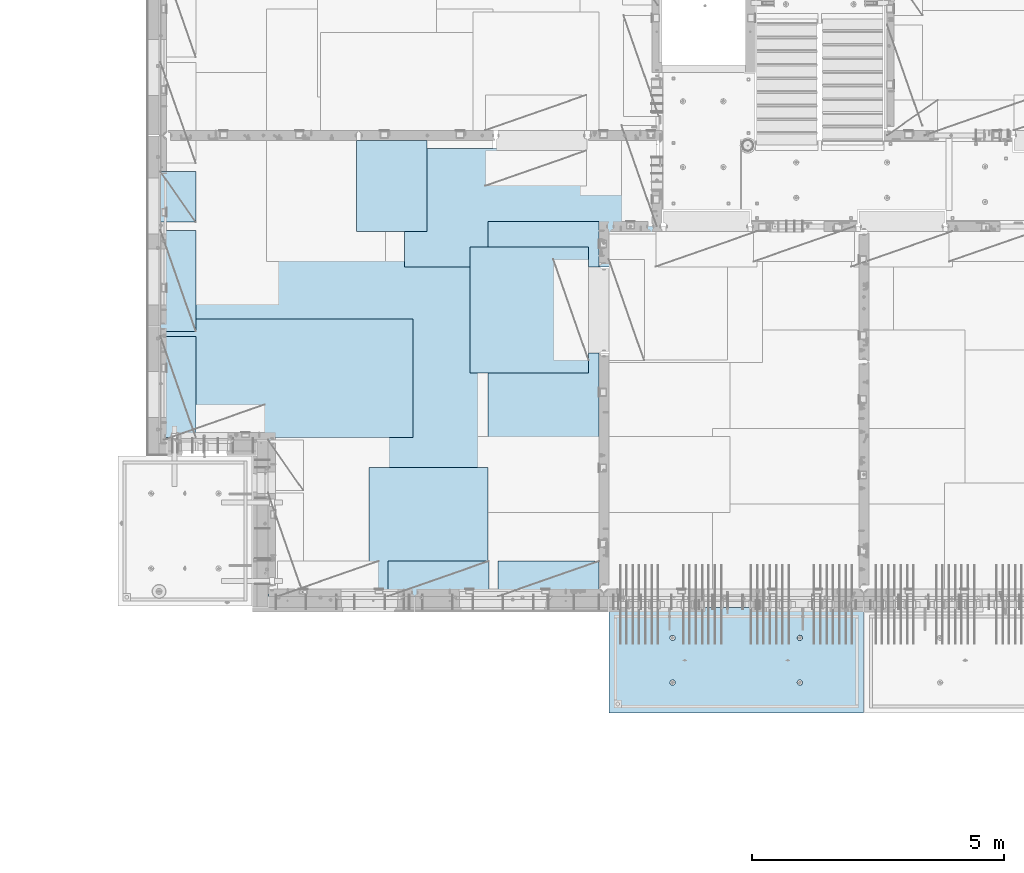
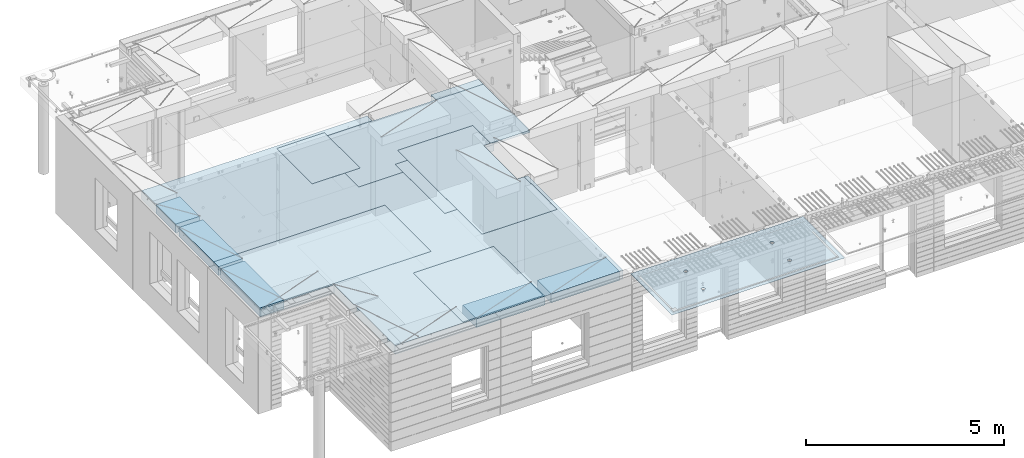
# One storey, part 201 of 350: 11 plates, 2 slabs, 11 elements without a shape of their own.
"""IFC2X3 building model written with IfcOpenShell, lengths in millimetres."""

from ifc_helpers import new_model, si_unit, frame, origin_with_axes, place, context, subcontext, project, spatial, faceted_brep, material, type_object, element, aggregate, save


model = new_model("IFC2X3")

# Units and contexts
model_context = context("Model", 3, precision=1e-05, world=origin_with_axes())
body_context = subcontext(model_context, "Body", "Model", "MODEL_VIEW")
ifc_project = project(units=[si_unit("LENGTHUNIT", "METRE", prefix="MILLI"), si_unit("AREAUNIT", "SQUARE_METRE"), si_unit("VOLUMEUNIT", "CUBIC_METRE"), si_unit("MASSUNIT", "GRAM", prefix="KILO"), si_unit("TIMEUNIT", "SECOND"), si_unit("PLANEANGLEUNIT", "RADIAN"), si_unit("SOLIDANGLEUNIT", "STERADIAN"), si_unit("THERMODYNAMICTEMPERATUREUNIT", "DEGREE_CELSIUS"), si_unit("LUMINOUSINTENSITYUNIT", "LUMEN")], contexts=[model_context])

# Site, building, storey
site_placement = place(None, origin_with_axes())
site = spatial("IfcSite", under=ifc_project, at=site_placement, CompositionType="ELEMENT")
building_placement = place(site_placement, origin_with_axes())
building = spatial("IfcBuilding", under=site, at=building_placement, CompositionType="ELEMENT")
storey_placement = place(building_placement, origin_with_axes())
storey = spatial("IfcBuildingStorey", under=building, at=storey_placement, Name="2", CompositionType="ELEMENT", Elevation=0.0)

# Assembly, slab
assembly_1_placement = place(storey_placement, origin_with_axes())
assembly_1 = element("IfcElementAssembly", 1, at=assembly_1_placement, inside=storey, AssemblyPlace="NOTDEFINED", PredefinedType="REINFORCEMENT_UNIT")
ifc_material_1 = material(Name="CONCRETE/C35/45")
slab_type_1 = type_object("IfcSlabType", PredefinedType="NOTDEFINED")
slab_1_placement = place(assembly_1_placement, frame((21799.9998568133, 7629.99655735226, 87720.0), z_axis=(-1.11800000013248e-06, -0.999999999999375, 0.0), x_axis=(-0.999999999999093, 1.34699999998405e-06, 0.0)))
slab_1 = element("IfcSlab", 2, at=slab_1_placement, type_object=slab_type_1, material=ifc_material_1, PredefinedType="FLOOR", context=body_context, shape_type="Brep", body=[
    faceted_brep([(3730.38290548735, -4.08996566387941, 616.12216176429), (3731.90567362447, 10.0, 615.627386703446), (3739.08833473806, 10.0, 629.724200466487), (3737.80580686752, -3.95055250760925, 630.656008831066), (3750.27560641379, 10.0, 640.911502705889), (3749.35118053074, -3.83997377335618, 642.183862123165), (3764.37240055375, 10.0, 648.094202331947), (3763.88889206625, -3.76900584615942, 649.582281527485), (3779.99882472937, 10.0, 650.569206660445), (3779.99882259584, -3.74455690493051, 652.131088126915), (3795.62525566664, 10.0, 648.094245023346), (3796.1087600739, -3.76900542440126, 649.582325494244), (3809.72206942968, 10.0, 640.911583909758), (3810.64649178305, -3.83997297089081, 642.183945778786), (3820.90937166908, 10.0, 629.724312234022), (3822.19189689232, -3.95055140258046, 630.656124028656), (3828.09207129514, 10.0, 615.627518094066), (3829.61483794004, -4.08996436404414, 616.122297269464), (3830.56707562364, 10.0, 600.001093918447), (3832.18578061358, -4.24460391153116, 600.001096129598), (3828.09211398654, 10.0, 584.374662981175), (3829.64831848373, -4.39934773846471, 583.869023838871), (3820.90945287295, 10.0, 570.277849218135), (3822.24608208202, -4.53903372617788, 569.306734043194), (3809.72218119721, 10.0, 559.090546978732), (3810.70070853473, -4.64994969953841, 557.743723511573), (3795.62538705726, 10.0, 551.907847352675), (3796.14233218844, -4.72119045964791, 550.316861227655), (3779.99896288164, 10.0, 549.432843024176), (3779.99896517058, -4.74574361447594, 547.757190340714), (3764.37253194437, 10.0, 551.907804661275), (3763.85559114489, -4.72119088313775, 550.316817078197), (3750.27571818133, 10.0, 559.090465774863), (3749.29719446955, -4.6499505048414, 557.743639560339), (3739.08841594193, 10.0, 570.277737450599), (3737.75178928409, -4.53903483404429, 569.306618549992), (3731.90571631587, 10.0, 584.374531590555), (3730.34951305942, -4.39934904004622, 583.868888150996), (3729.43071198737, 10.0, 600.000955766174), (3727.81200684201, -4.24460527917836, 600.000953555023), (0.0, 10.0, 0.0), (0.0, -10.0, 0.0), (0.000328360383718973, 10.0, 2085.00366210938), (5040.0, 10.0, -2.18278728425503e-09), (5040.0, -10.0, -2.18278728425503e-09), (5040.00048828125, 10.0, 2085.00366210938), (1210.18496592851, 4.0893025782425, 1468.8123736889), (1210.82376192895, 10.0, 1469.01993205604), (1208.29313952565, 10.0, 1484.99751183111), (1207.63911173254, 4.24455542066426, 1484.99751093771), (1217.61159442581, 3.94915724093153, 1454.20219661341), (1218.16787053537, 10.0, 1454.6063560253), (1229.19498209749, 3.837876675796, 1442.60117732261), (1229.60657282509, 10.0, 1443.16768498606), (1243.80127350603, 3.76640192835475, 1435.14992181469), (1244.02016891989, 10.0, 1435.82361575756), (1259.99775658, 3.74176842256566, 1432.58187432577), (1259.99775560856, 10.0, 1433.29303700502), (1276.19423262309, 3.76640235324157, 1435.14996610939), (1275.97533538363, 10.0, 1435.82365940832), (1290.8005036357, 3.83787748374743, 1442.60126155003), (1290.38891141437, 10.0, 1443.16776801473), (1302.38385956513, 3.94915835243592, 1454.20231248656), (1301.82758245361, 10.0, 1454.60647030446), (1309.81044810845, 4.08930388411682, 1468.81250982317), (1309.17165168211, 10.0, 1469.02006639926), (1312.35625807182, 4.244556792808, 1484.99765398133), (1311.70223043464, 10.0, 1484.99765308793), (1309.77685741928, 4.39970507899125, 1501.17189122433), (1309.17160803135, 10.0, 1500.975232863), (1302.32949611505, 4.53957668620569, 1515.75353188573), (1301.82749942493, 10.0, 1515.38880889374), (1290.74610851982, 4.65051890275208, 1527.31927827547), (1290.3887971352, 10.0, 1526.82747993297), (1276.16055006181, 4.72171992080985, 1534.74199744468), (1275.97520104041, 10.0, 1534.17154916147), (1259.99761353621, 4.74624887190294, 1537.29914508766), (1259.99761435174, 10.0, 1536.70212791401), (1243.83468398195, 4.72171949766926, 1534.74195333328), (1244.02003457667, 10.0, 1534.17150551072), (1229.24914576394, 4.65051809765282, 1527.31919434463), (1229.60645854592, 10.0, 1526.8273969043), (1217.66578971822, 4.53957557752437, 1515.75341630916), (1218.16778750669, 10.0, 1515.38869461457), (1210.21846821205, 4.39970377489226, 1501.17175527336), (1210.82371827819, 10.0, 1500.97509851978), (1210.34950957413, -4.39938207223895, 583.86544460908), (1211.90571640051, 10.0, 584.371089208588), (1209.43071207202, 10.0, 599.997513384207), (1207.81200317426, -4.24463830025343, 599.997511173051), (1217.75178633104, -4.53906787629239, 569.303173961003), (1219.08841602657, 10.0, 570.274295068632), (1229.29719234665, -4.64998355506395, 557.740194139937), (1230.27571826597, 10.0, 559.087023392896), (1243.85559006878, -4.72122393849713, 550.313371123784), (1244.37253202901, 10.0, 551.904362279308), (1259.99896525523, -4.74577667158155, 547.753744202259), (1259.99896296629, 10.0, 549.429400642209), (1276.14233343384, -4.72122351497819, 550.313415273247), (1275.6253871419, 10.0, 551.904404970708), (1290.70071082692, -4.64998274977552, 557.740278091178), (1289.72218128186, 10.0, 559.087104596765), (1302.24608520437, -4.53906676842598, 569.303289454215), (1300.9094529576, 10.0, 570.274406836168), (1309.64832213832, -4.39938077065744, 583.865580296964), (1308.09211407118, 10.0, 584.371220599208), (1312.18578445062, -4.24463693260623, 599.997653747636), (1310.56707570828, 10.0, 599.99765153648), (1309.61484159223, -4.08999737400154, 616.118856046664), (1308.09207137979, 10.0, 615.624075712099), (1302.19190001076, -3.95058440251159, 630.652683850883), (1300.90937175373, 10.0, 629.720869852055), (1290.64649407134, -3.8400059628766, 642.180506429899), (1289.72206951433, 10.0, 640.908141527791), (1276.10876131689, -3.76903841129388, 649.578886677323), (1275.62525575129, 10.0, 648.090802641378), (1259.99882268048, -3.74458989004779, 652.127649493255), (1259.99882481401, 10.0, 650.565764278478), (1243.88889099253, -3.76903883303748, 649.578842710559), (1244.37240063839, 10.0, 648.090759949978), (1229.35117841172, -3.84000676534197, 642.180422774271), (1230.27560649844, 10.0, 640.908060323922), (1217.80580391836, -3.95058550754038, 630.652568653284), (1219.0883348227, 10.0, 629.72075808452), (1210.38290200446, -4.08999867383682, 616.11872054148), (1211.90567370912, 10.0, 615.623944321479), (3795.97520095576, 10.0, 1534.17499154344), (3796.16054881881, 4.72175290768791, 1534.7454362616), (3779.99761345157, 4.74628185702022, 1537.30258372132), (3779.99761426709, 10.0, 1536.70557029598), (3810.38879705055, 10.0, 1526.83092231494), (3810.74610623151, 4.65055189473787, 1527.32271762435), (3821.82749934028, 10.0, 1515.39225127571), (3822.3294929966, 4.53960968612228, 1515.75697206351), (3829.1716079467, 10.0, 1500.97867524496), (3829.7768537671, 4.39973808894865, 1501.17533244712), (3831.70223035, 10.0, 1485.00109546989), (3832.35625423479, 4.24458981388307, 1485.00109636329), (3829.17165159746, 10.0, 1469.02350878122), (3829.81044445387, 4.08933691630955, 1468.81595336508), (3821.82758236896, 10.0, 1454.60991268643), (3822.38385644279, 3.94919139468402, 1454.20575707554), (3810.38891132972, 10.0, 1443.1712103967), (3810.8005013435, 3.83791053396999, 1442.60470697043), (3795.97533529899, 10.0, 1435.82710179029), (3796.19423137769, 3.76643540860096, 1435.1534120638), (3779.99775552391, 10.0, 1433.29647938699), (3779.99775649536, 3.74180147968582, 1432.58532046422), (3764.02016883524, 10.0, 1435.82705813953), (3763.80127458214, 3.76643498368503, 1435.1533677691), (3749.60657274045, 10.0, 1443.17112736803), (3749.19498422039, 3.837909726004, 1442.60462274301), (3738.16787045072, 10.0, 1454.60979840726), (3737.61159737886, 3.94919028317963, 1454.2056412024), (3730.82376184431, 10.0, 1469.023374438), (3730.18496941381, 4.08933561044978, 1468.81581723082), (3737.66579266739, 4.53960857747006, 1515.75685648694), (3749.24914788297, 4.65055108962406, 1527.32263369353), (3763.83468505566, 4.72175248454732, 1534.7453921502), (3727.63911540029, 4.24458844172477, 1485.00095331968), (3730.21847169495, 4.39973678484967, 1501.17519649617), (3764.02003449202, 10.0, 1534.17494789268), (3749.60645846128, 10.0, 1526.83083928627), (3738.16778742204, 10.0, 1515.39213699654), (3730.82371819355, 10.0, 1500.97854090175), (3728.293139441, 10.0, 1485.00095421308)], [[[0, 1, 2, 3]], [[3, 2, 4, 5]], [[5, 4, 6, 7]], [[7, 6, 8, 9]], [[10, 11, 9, 8]], [[12, 13, 11, 10]], [[14, 15, 13, 12]], [[16, 17, 15, 14]], [[18, 19, 17, 16]], [[20, 21, 19, 18]], [[22, 23, 21, 20]], [[24, 25, 23, 22]], [[26, 27, 25, 24]], [[27, 26, 28, 29]], [[29, 28, 30, 31]], [[31, 30, 32, 33]], [[33, 32, 34, 35]], [[35, 34, 36, 37]], [[37, 36, 38, 39]], [[39, 38, 1, 0]], [[40, 41, 42]], [[40, 43, 44, 41]], [[43, 45, 44]], [[46, 47, 48, 49]], [[50, 51, 47, 46]], [[52, 53, 51, 50]], [[54, 55, 53, 52]], [[56, 57, 55, 54]], [[58, 59, 57, 56]], [[60, 61, 59, 58]], [[61, 60, 62, 63]], [[63, 62, 64, 65]], [[65, 64, 66, 67]], [[67, 66, 68, 69]], [[69, 68, 70, 71]], [[71, 70, 72, 73]], [[73, 72, 74, 75]], [[75, 74, 76, 77]], [[77, 76, 78, 79]], [[80, 81, 79, 78]], [[82, 83, 81, 80]], [[84, 85, 83, 82]], [[49, 48, 85, 84]], [[86, 87, 88, 89]], [[90, 91, 87, 86]], [[92, 93, 91, 90]], [[94, 95, 93, 92]], [[96, 97, 95, 94]], [[98, 99, 97, 96]], [[99, 98, 100, 101]], [[101, 100, 102, 103]], [[103, 102, 104, 105]], [[105, 104, 106, 107]], [[107, 106, 108, 109]], [[109, 108, 110, 111]], [[111, 110, 112, 113]], [[113, 112, 114, 115]], [[115, 114, 116, 117]], [[118, 119, 117, 116]], [[120, 121, 119, 118]], [[122, 123, 121, 120]], [[124, 125, 123, 122]], [[89, 88, 125, 124]], [[126, 127, 128, 129]], [[130, 131, 127, 126]], [[132, 133, 131, 130]], [[134, 135, 133, 132]], [[136, 137, 135, 134]], [[138, 139, 137, 136]], [[140, 141, 139, 138]], [[142, 143, 141, 140]], [[143, 142, 144, 145]], [[145, 144, 146, 147]], [[147, 146, 148, 149]], [[149, 148, 150, 151]], [[151, 150, 152, 153]], [[153, 152, 154, 155]], [[41, 44, 45, 42], [3, 5, 7, 9, 11, 13, 15, 17, 19, 21, 23, 25, 27, 29, 31, 33, 35, 37, 39, 0], [156, 157, 158, 128, 127, 131, 133, 135, 137, 139, 141, 143, 145, 147, 149, 151, 153, 155, 159, 160], [122, 120, 118, 116, 114, 112, 110, 108, 106, 104, 102, 100, 98, 96, 94, 92, 90, 86, 89, 124], [82, 80, 78, 76, 74, 72, 70, 68, 66, 64, 62, 60, 58, 56, 54, 52, 50, 46, 49, 84]], [[129, 128, 158, 161]], [[157, 162, 161, 158]], [[156, 163, 162, 157]], [[160, 164, 163, 156]], [[159, 165, 164, 160]], [[155, 154, 165, 159]], [[43, 40, 42, 45], [34, 32, 30, 28, 26, 24, 22, 20, 18, 16, 14, 12, 10, 8, 6, 4, 2, 1, 38, 36], [152, 150, 148, 146, 144, 142, 140, 138, 136, 134, 132, 130, 126, 129, 161, 162, 163, 164, 165, 154], [91, 93, 95, 97, 99, 101, 103, 105, 107, 109, 111, 113, 115, 117, 119, 121, 123, 125, 88, 87], [51, 53, 55, 57, 59, 61, 63, 65, 67, 69, 71, 73, 75, 77, 79, 81, 83, 85, 48, 47]]]),
])
aggregate(assembly_1, [slab_1])

# Assembly, plate
assembly_2_placement = place(storey_placement, origin_with_axes())
assembly_2 = element("IfcElementAssembly", 3, at=assembly_2_placement, inside=storey, Name="Steel Assembly", AssemblyPlace="NOTDEFINED", PredefinedType="NOTDEFINED")
ifc_material_2 = material()
plate_type_1 = type_object("IfcPlateType", PredefinedType="NOTDEFINED")
plate_1_placement = place(assembly_2_placement, frame((14009.7695320312, 12275.0000289158, 87695.1), z_axis=(0.0, 1.0, 0.0), x_axis=(1.0, 0.0, 0.0)))
plate_1 = element("IfcPlate", 4, at=plate_1_placement, type_object=plate_type_1, material=ifc_material_2, Name="1/2", context=body_context, shape_type="Brep", body=[
    faceted_brep([(0.0, -35.0, 0.0), (0.0, -35.0, 2500.0), (0.0, 35.0, 2500.0), (0.0, 35.0, 0.0), (2349.99951171875, -35.0, 2500.0), (2349.99951171875, 35.0, 2500.0), (2350.0, -35.0, 0.0), (2350.0, 35.0, 0.0)], [[[0, 1, 2, 3]], [[1, 4, 5, 2]], [[4, 6, 7, 5]], [[6, 0, 3, 7]], [[5, 7, 3, 2]], [[6, 4, 1, 0]]]),
])
aggregate(assembly_2, [plate_1])

assembly_3_placement = place(storey_placement, origin_with_axes())
assembly_3 = element("IfcElementAssembly", 5, at=assembly_3_placement, inside=storey, Name="Steel Assembly", AssemblyPlace="NOTDEFINED", PredefinedType="NOTDEFINED")
plate_2_placement = place(assembly_3_placement, frame((14360.0, 10400.0, 87695.1), z_axis=(0.0, -1.0, 0.0), x_axis=(-1.0, 3.00000001838171e-08, 0.0)))
plate_2 = element("IfcPlate", 6, at=plate_2_placement, type_object=plate_type_1, material=ifc_material_2, Name="1/2", context=body_context, shape_type="Brep", body=[
    faceted_brep([(0.0, -35.0, 0.0), (0.0, -35.0, 2500.0), (0.0, 35.0, 2500.0), (0.0, 35.0, 0.0), (2349.99951171875, -35.0, 2500.0), (2349.99951171875, 35.0, 2500.0), (2350.0, -35.0, 0.0), (2350.0, 35.0, 0.0)], [[[0, 1, 2, 3]], [[1, 4, 5, 2]], [[4, 6, 7, 5]], [[6, 0, 3, 7]], [[5, 7, 3, 2]], [[6, 4, 1, 0]]]),
])
aggregate(assembly_3, [plate_2])

assembly_4_placement = place(storey_placement, origin_with_axes())
assembly_4 = element("IfcElementAssembly", 7, at=assembly_4_placement, inside=storey, Name="Steel Assembly", AssemblyPlace="NOTDEFINED", PredefinedType="NOTDEFINED")
plate_3_placement = place(assembly_4_placement, frame((12710.0, 16725.0, 87695.1), z_axis=(1.0, 0.0, 0.0), x_axis=(0.0, -1.0, 0.0)))
plate_3 = element("IfcPlate", 8, at=plate_3_placement, type_object=plate_type_1, material=ifc_material_2, context=body_context, shape_type="Brep", body=[
    faceted_brep([(0.0, -35.0, 0.0), (0.0, -35.0, 5000.0), (0.0, 35.0, 5000.0), (0.0, 35.0, 0.0), (2349.99951171875, -35.0, 5000.0), (2349.99951171875, 35.0, 5000.0), (2350.0, -35.0, 0.0), (2350.0, 35.0, 0.0)], [[[0, 1, 2, 3]], [[1, 4, 5, 2]], [[4, 6, 7, 5]], [[6, 0, 3, 7]], [[5, 7, 3, 2]], [[6, 4, 1, 0]]]),
])
aggregate(assembly_4, [plate_3])

assembly_5_placement = place(storey_placement, origin_with_axes())
assembly_5 = element("IfcElementAssembly", 9, at=assembly_5_placement, inside=storey, Name="Steel Assembly", AssemblyPlace="NOTDEFINED", PredefinedType="NOTDEFINED")
plate_4_placement = place(assembly_5_placement, frame((12880.0, 11000.0, 87695.1), z_axis=(-1.0, 3.00000001838171e-08, 0.0), x_axis=(0.0, 1.0, 0.0)))
plate_4 = element("IfcPlate", 10, at=plate_4_placement, type_object=plate_type_1, material=ifc_material_2, context=body_context, shape_type="Brep", body=[
    faceted_brep([(0.0, -35.0, 0.0), (0.0, -35.0, 5000.0), (0.0, 35.0, 5000.0), (0.0, 35.0, 0.0), (2349.99951171875, -35.0, 5000.0), (2349.99951171875, 35.0, 5000.0), (2350.0, -35.0, 0.0), (2350.0, 35.0, 0.0)], [[[0, 1, 2, 3]], [[1, 4, 5, 2]], [[4, 6, 7, 5]], [[6, 0, 3, 7]], [[5, 7, 3, 2]], [[6, 4, 1, 0]]]),
])
aggregate(assembly_5, [plate_4])

assembly_6_placement = place(storey_placement, origin_with_axes())
assembly_6 = element("IfcElementAssembly", 11, at=assembly_6_placement, inside=storey, Name="Steel Assembly", AssemblyPlace="NOTDEFINED", PredefinedType="NOTDEFINED")
plate_type_2 = type_object("IfcPlateType", PredefinedType="NOTDEFINED")
plate_5_placement = place(assembly_6_placement, frame((7879.99987792969, 13000.0, 87595.3), z_axis=(1.0, 0.0, 0.0), x_axis=(0.0, -1.0, 0.0)))
plate_5 = element("IfcPlate", 12, at=plate_5_placement, type_object=plate_type_2, material=ifc_material_2, Name="RE1", context=body_context, shape_type="Brep", body=[
    faceted_brep([(1.81898940354586e-12, -135.0, 1.81898940354586e-12), (0.0, -135.0, 699.999999999996), (0.0, 135.0, 699.999999999996), (1.81898940354586e-12, 135.0, 1.81898940354586e-12), (1999.99951171875, -135.0, 699.999999999993), (1999.99951171875, 135.0, 699.999999999993), (2000.0, -135.0, -3.63797880709171e-12), (2000.0, 135.0, -3.63797880709171e-12)], [[[0, 1, 2, 3]], [[1, 4, 5, 2]], [[4, 6, 7, 5]], [[6, 0, 3, 7]], [[5, 7, 3, 2]], [[6, 4, 1, 0]]]),
])
aggregate(assembly_6, [plate_5])

assembly_7_placement = place(storey_placement, origin_with_axes())
assembly_7 = element("IfcElementAssembly", 13, at=assembly_7_placement, inside=storey, Name="Steel Assembly", AssemblyPlace="NOTDEFINED", PredefinedType="NOTDEFINED")
plate_6_placement = place(assembly_7_placement, frame((7879.99999992931, 16265.0, 87595.3), z_axis=(1.0, 0.0, 0.0), x_axis=(0.0, -1.0, 0.0)))
plate_6 = element("IfcPlate", 14, at=plate_6_placement, type_object=plate_type_2, material=ifc_material_2, Name="RE1_1/2", context=body_context, shape_type="Brep", body=[
    faceted_brep([(1.81898940354586e-12, -135.0, 1.81898940354586e-12), (0.0, -135.0, 699.999999999996), (0.0, 135.0, 699.999999999996), (1.81898940354586e-12, 135.0, 1.81898940354586e-12), (999.99951171875, -135.0, 700.0), (999.99951171875, 135.0, 700.0), (1000.0, -135.0, 0.0), (1000.0, 135.0, 0.0)], [[[0, 1, 2, 3]], [[1, 4, 5, 2]], [[4, 6, 7, 5]], [[6, 0, 3, 7]], [[5, 7, 3, 2]], [[6, 4, 1, 0]]]),
])
aggregate(assembly_7, [plate_6])

assembly_8_placement = place(storey_placement, origin_with_axes())
assembly_8 = element("IfcElementAssembly", 15, at=assembly_8_placement, inside=storey, Name="Steel Assembly", AssemblyPlace="NOTDEFINED", PredefinedType="NOTDEFINED")
plate_7_placement = place(assembly_8_placement, frame((14565.0008542386, 7850.00010363356, 87595.3), z_axis=(0.0, 1.0, 0.0), x_axis=(1.0, 0.0, 0.0)))
plate_7 = element("IfcPlate", 16, at=plate_7_placement, type_object=plate_type_2, material=ifc_material_2, Name="RE1", context=body_context, shape_type="Brep", body=[
    faceted_brep([(1.81898940354586e-12, -135.0, 1.81898940354586e-12), (0.0, -135.0, 699.999999999996), (0.0, 135.0, 699.999999999996), (1.81898940354586e-12, 135.0, 1.81898940354586e-12), (1999.99951171875, -135.0, 699.999999999993), (1999.99951171875, 135.0, 699.999999999993), (2000.0, -135.0, -3.63797880709171e-12), (2000.0, 135.0, -3.63797880709171e-12)], [[[0, 1, 2, 3]], [[1, 4, 5, 2]], [[4, 6, 7, 5]], [[6, 0, 3, 7]], [[5, 7, 3, 2]], [[6, 4, 1, 0]]]),
])
aggregate(assembly_8, [plate_7])

assembly_9_placement = place(storey_placement, origin_with_axes())
assembly_9 = element("IfcElementAssembly", 17, at=assembly_9_placement, inside=storey, Name="Steel Assembly", AssemblyPlace="NOTDEFINED", PredefinedType="NOTDEFINED")
plate_8_placement = place(assembly_9_placement, frame((12382.5008542386, 7850.00010363356, 87595.3), z_axis=(0.0, 1.0, 0.0), x_axis=(1.0, 0.0, 0.0)))
plate_8 = element("IfcPlate", 18, at=plate_8_placement, type_object=plate_type_2, material=ifc_material_2, Name="RE1", context=body_context, shape_type="Brep", body=[
    faceted_brep([(1.81898940354586e-12, -135.0, 1.81898940354586e-12), (0.0, -135.0, 699.999999999996), (0.0, 135.0, 699.999999999996), (1.81898940354586e-12, 135.0, 1.81898940354586e-12), (1999.99951171875, -135.0, 699.999999999993), (1999.99951171875, 135.0, 699.999999999993), (2000.0, -135.0, -3.63797880709171e-12), (2000.0, 135.0, -3.63797880709171e-12)], [[[0, 1, 2, 3]], [[1, 4, 5, 2]], [[4, 6, 7, 5]], [[6, 0, 3, 7]], [[5, 7, 3, 2]], [[6, 4, 1, 0]]]),
])
aggregate(assembly_9, [plate_8])

assembly_10_placement = place(storey_placement, origin_with_axes())
assembly_10 = element("IfcElementAssembly", 19, at=assembly_10_placement, inside=storey, Name="Steel Assembly", AssemblyPlace="NOTDEFINED", PredefinedType="NOTDEFINED")
plate_9_placement = place(assembly_10_placement, frame((7879.99987792969, 15100.0, 87595.3), z_axis=(1.0, 0.0, 0.0), x_axis=(0.0, -1.0, 0.0)))
plate_9 = element("IfcPlate", 20, at=plate_9_placement, type_object=plate_type_2, material=ifc_material_2, Name="RE1", context=body_context, shape_type="Brep", body=[
    faceted_brep([(1.81898940354586e-12, -135.0, 1.81898940354586e-12), (0.0, -135.0, 699.999999999996), (0.0, 135.0, 699.999999999996), (1.81898940354586e-12, 135.0, 1.81898940354586e-12), (1999.99951171875, -135.0, 699.999999999993), (1999.99951171875, 135.0, 699.999999999993), (2000.0, -135.0, -3.63797880709171e-12), (2000.0, 135.0, -3.63797880709171e-12)], [[[0, 1, 2, 3]], [[1, 4, 5, 2]], [[4, 6, 7, 5]], [[6, 0, 3, 7]], [[5, 7, 3, 2]], [[6, 4, 1, 0]]]),
])
aggregate(assembly_10, [plate_9])

# Assembly, plates, slab
assembly_11_placement = place(storey_placement, origin_with_axes())
assembly_11 = element("IfcElementAssembly", 21, at=assembly_11_placement, inside=storey, AssemblyPlace="NOTDEFINED", PredefinedType="REINFORCEMENT_UNIT")
plate_type_3 = type_object("IfcPlateType", PredefinedType="NOTDEFINED")
plate_10_placement = place(assembly_11_placement, frame((13159.9998642727, 15079.9997757405, 87725.45), z_axis=(-1.0, 3.00000001838171e-08, 0.0), x_axis=(0.0, 1.0, 0.0)))
plate_10 = element("IfcPlate", 22, at=plate_10_placement, type_object=plate_type_3, material=ifc_material_2, context=body_context, shape_type="Brep", body=[
    faceted_brep([(0.0, -5.0, 0.0), (0.0, -5.0, 1399.99963378906), (0.0, 5.0, 1399.99963378906), (0.0, 5.0, 0.0), (1800.00024414063, -5.0, 1399.99963378906), (1800.00024414063, 5.0, 1399.99963378906), (1800.00024414063, -5.0, 0.0), (1800.00024414063, 5.0, 0.0)], [[[0, 1, 2, 3]], [[1, 4, 5, 2]], [[4, 6, 7, 5]], [[6, 0, 3, 7]], [[5, 7, 3, 2]], [[6, 4, 1, 0]]]),
])
plate_type_4 = type_object("IfcPlateType", PredefinedType="NOTDEFINED")
plate_11_placement = place(assembly_11_placement, frame((16559.9994828029, 15279.9995850056, 87725.45), z_axis=(0.0, -1.0, 0.0), x_axis=(-1.0, 3.00000001838171e-08, 0.0)))
plate_11 = element("IfcPlate", 23, at=plate_11_placement, type_object=plate_type_4, material=ifc_material_2, context=body_context, shape_type="Brep", body=[
    faceted_brep([(0.0, -5.0, 2604.99950854713), (0.0, 5.0, 2604.99950854713), (200.234115600586, 5.0, 2604.99950854713), (200.234115600586, -5.0, 2604.99950854713), (200.234115600586, 5.0, 904.999508547127), (200.234115600586, -5.0, 904.999508547127), (0.0, -5.0, 904.999508547127), (0.0, 5.0, 904.999508547127), (0.0, -5.0, 4271.99951171875), (2191.99951171875, -5.0, 4271.99951171875), (2191.99951171875, 5.0, 4271.99951171875), (0.0, 5.0, 4271.99951171875), (2191.99951171875, -5.0, 0.0), (2191.99951171875, 5.0, 0.0), (0.0, -5.0, 0.0), (0.0, 5.0, 0.0)], [[[0, 1, 2, 3]], [[3, 2, 4, 5]], [[6, 5, 4, 7]], [[8, 9, 10, 11]], [[9, 12, 13, 10]], [[12, 14, 15, 13]], [[15, 14, 6, 7]], [[2, 1, 11, 10, 13, 15, 7, 4]], [[8, 11, 1, 0]], [[14, 12, 9, 8, 0, 3, 5, 6]]]),
])
ifc_material_3 = material(Name="CONCRETE/C30/37")
slab_type_2 = type_object("IfcSlabType", PredefinedType="NOTDEFINED")
slab_2_placement = place(assembly_11_placement, frame((10010.0, 7850.0, 87595.0), z_axis=(0.0, 1.0, 0.0), x_axis=(1.0, 0.0, 0.0)))
slab_2 = element("IfcSlab", 24, at=slab_2_placement, type_object=slab_type_2, material=ifc_material_3, PredefinedType="FLOOR", context=body_context, shape_type="Brep", body=[
    faceted_brep([(4453.68914550781, -135.0, 9130.0), (-2130.0, -135.0, 9130.0), (-2130.0, -135.0, 3100.0), (0.0, -135.0, 3100.0), (1.81898940354586e-12, -135.0, 1.81898940354586e-12), (6650.0, -135.0, 0.0), (6650.0, -135.0, 4825.00007645847), (6349.76536720235, -135.0, 4825.00007645847), (6349.76536720235, -135.0, 6525.00007645847), (6649.99998634297, -135.0, 6525.00007645847), (6650.0, -135.0, 7330.0), (7700.0, -135.0, 7330.0), (7700.0, -135.0, 9130.0), (6319.99914550781, -135.0, 9130.0), (6319.99914550781, -135.0, 8830.0), (6153.68914550781, -135.0, 8830.0), (4520.0, -135.0, 8830.0), (4453.69, -135.0, 8830.0), (-2130.0, 135.0, 9130.0), (4453.68914550781, 135.0, 9130.0), (-2130.0, 135.0, 3100.0), (0.0, 135.0, 3100.0), (1.81898940354586e-12, 135.0, 1.81898940354586e-12), (6650.0, 135.0, 0.0), (6650.0, 135.0, 4825.00007645847), (6349.76536720235, 135.0, 4825.00007645847), (6349.76536720235, 135.0, 6525.00007645847), (6650.0, 135.0, 6525.00007645847), (6650.0, 135.0, 7330.0), (7700.0, 135.0, 7330.0), (7700.0, 135.0, 9130.0), (6319.99914550781, 135.0, 9130.0), (6319.99914550781, 135.0, 8830.0), (6153.68914550781, 135.0, 8830.0), (4520.0, 135.0, 8830.0), (4453.69, 135.0, 8830.0)], [[[0, 1, 2, 3, 4, 5, 6, 7, 8, 9, 10, 11, 12, 13, 14, 15, 16, 17]], [[18, 1, 0, 19]], [[2, 1, 18, 20]], [[3, 2, 20, 21]], [[4, 3, 21, 22]], [[5, 4, 22, 23]], [[5, 23, 24, 6]], [[6, 24, 25, 7]], [[7, 25, 26, 8]], [[9, 8, 26, 27]], [[28, 10, 9, 27]], [[11, 10, 28, 29]], [[12, 11, 29, 30]], [[12, 30, 31, 13]], [[13, 31, 32, 14]], [[15, 14, 32, 33, 34, 16]], [[16, 34, 35, 17]], [[33, 32, 31, 30, 29, 28, 27, 26, 25, 24, 23, 22, 21, 20, 18, 19, 35, 34]], [[0, 17, 35, 19]]]),
])
aggregate(assembly_11, [plate_10, plate_11, slab_2])

save(model, "model.ifc")
